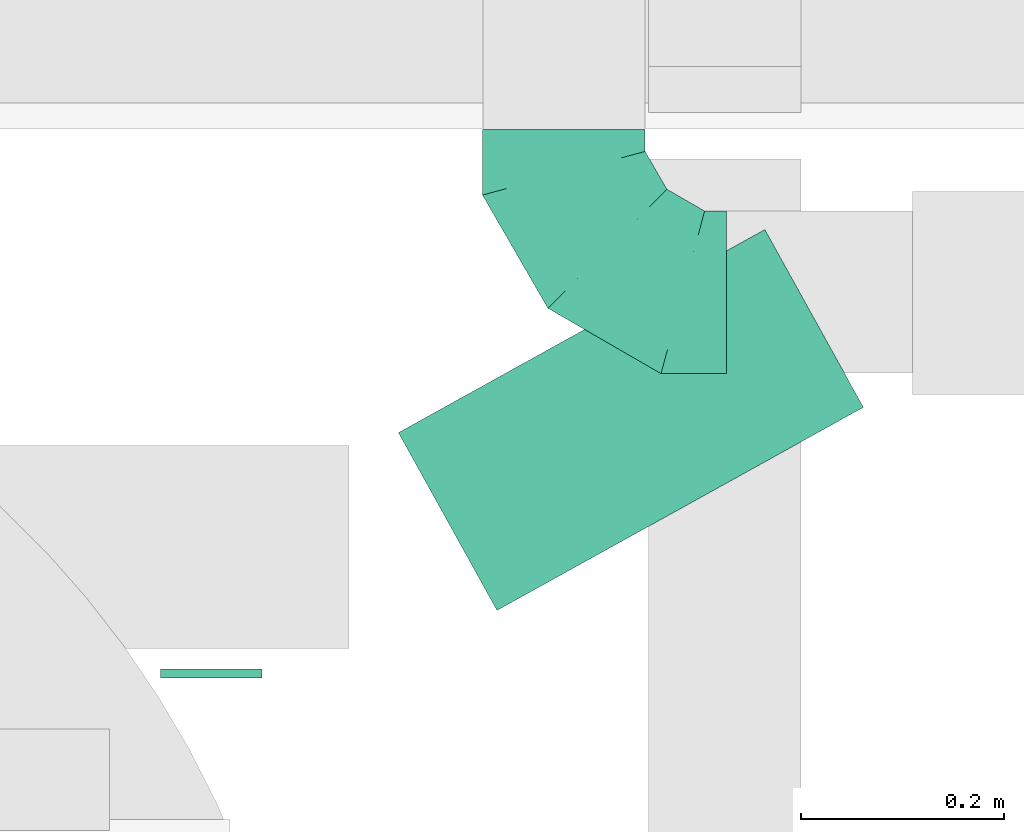
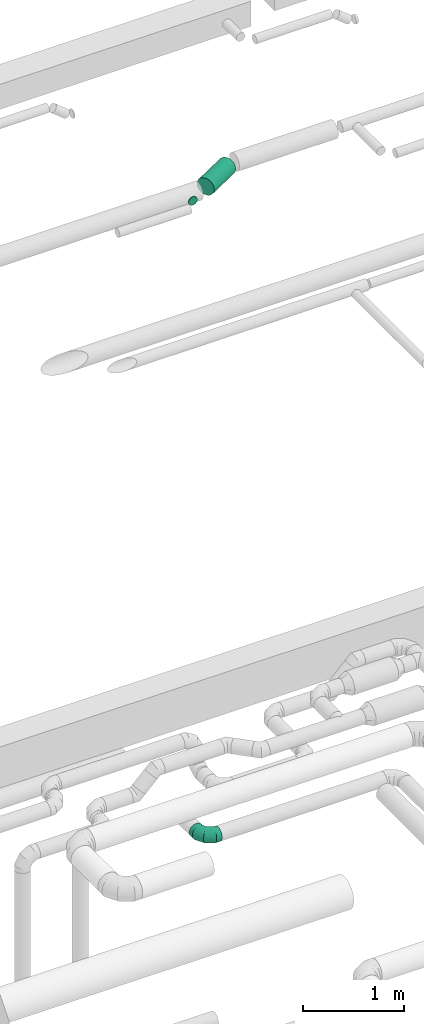
# One storey, part 284 of 337: 2 flow segments, 1 flow fitting.
"""IFC2X3 building model written with IfcOpenShell, lengths in millimetres."""

import ifcopenshell
import ifcopenshell.guid

model = None  # the IFC model being written
_history = None  # IfcOwnerHistory: only IFC2X3 demands one
_inside = {}  # id of a spatial element -> (the spatial element, [elements in it])
_under = {}  # id of a project, library or spatial element -> (it, [spatial elements below it])
_declared = {}  # id of a project -> (the project, [libraries it declares])
_typed = {}  # id of a type object -> (the type object, [elements of that type])
_made_of = {}  # id of a material, layer set ... -> (it, [elements and type objects made of it])


def new_model(schema):
    """Start an empty IFC model of exactly this schema.

    Asked for "IFC4X3", IfcOpenShell would pick the latest addendum, in which some entities
    have other attributes; the version numbers below select the first issue.
    IFC2X3 requires an IfcOwnerHistory on every rooted entity: one is made here for all.
    """
    global model, _history
    if schema == "IFC4X3":
        model = ifcopenshell.file(schema_version=(4, 3, 0, 0))
    else:
        model = ifcopenshell.file(schema=schema)
    _inside.clear()
    _under.clear()
    _declared.clear()
    _typed.clear()
    _made_of.clear()
    _history = None
    if model.schema == "IFC2X3":
        org = make("IfcOrganization", Name="unknown")
        user = make(
            "IfcPersonAndOrganization",
            ThePerson=make("IfcPerson", FamilyName="unknown"),
            TheOrganization=org,
        )
        app = make(
            "IfcApplication",
            ApplicationDeveloper=org,
            Version="unknown",
            ApplicationFullName="unknown",
            ApplicationIdentifier="unknown",
        )
        _history = make(
            "IfcOwnerHistory",
            OwningUser=user,
            OwningApplication=app,
            ChangeAction="ADDED",
            CreationDate=0,
        )
    return model


def make(cls, **values):
    """One entity of the class cls with the attributes given. An attribute that is None is left unset."""
    return model.create_entity(
        cls, **{name: value for name, value in values.items() if value is not None}
    )


def entity(cls, *values):
    """Any entity or typed value of the class cls, its attributes in the order of the schema. None: left unset."""
    e = model.create_entity(cls)
    for i, value in enumerate(values):
        if value is not None:
            e[i] = value
    return e


def rooted(cls, **values):
    """An entity with a GlobalId (a new one), such as an element, a storey or a relation."""
    return make(cls, GlobalId=ifcopenshell.guid.new(), OwnerHistory=_history, **values)


def si_unit(unit_type, name, prefix=None):
    """IfcSIUnit, for example si_unit("LENGTHUNIT", "METRE", prefix="MILLI")."""
    return make("IfcSIUnit", UnitType=unit_type, Prefix=prefix, Name=name)


def converted_unit(unit_type, name, factor, base, dimensions=None, offset=None):
    """IfcConversionBasedUnit, such as the inch: factor (a typed value) times the base unit."""
    return make(
        "IfcConversionBasedUnit"
        if offset is None
        else "IfcConversionBasedUnitWithOffset",
        ConversionOffset=offset,
        Dimensions=None
        if dimensions is None
        else entity("IfcDimensionalExponents", *dimensions),
        UnitType=unit_type,
        Name=name,
        ConversionFactor=make(
            "IfcMeasureWithUnit", ValueComponent=factor, UnitComponent=base
        ),
    )


def derived_unit(unit_type, elements):
    """IfcDerivedUnit: a product of units, each with its exponent."""
    return make(
        "IfcDerivedUnit",
        Elements=[
            make("IfcDerivedUnitElement", Unit=unit, Exponent=power)
            for unit, power in elements
        ],
        UnitType=unit_type,
    )


def assignment(units):
    """IfcUnitAssignment: the units of a project."""
    return None if units is None else make("IfcUnitAssignment", Units=units)


def point(xyz):
    """IfcCartesianPoint."""
    return None if xyz is None else make("IfcCartesianPoint", Coordinates=xyz)


def direction(xyz):
    """IfcDirection."""
    return None if xyz is None else make("IfcDirection", DirectionRatios=xyz)


def frame(location, z_axis=None, x_axis=None):
    """IfcAxis2Placement3D, a coordinate frame: its origin and axes. An axis left out is left unset."""
    return make(
        "IfcAxis2Placement3D",
        Location=point(location),
        Axis=direction(z_axis),
        RefDirection=direction(x_axis),
    )


def frame_2d(location, x_axis=None):
    """IfcAxis2Placement2D, a coordinate frame in the plane: its origin and x axis."""
    return make(
        "IfcAxis2Placement2D", Location=point(location), RefDirection=direction(x_axis)
    )


def origin():
    """The frame at (0, 0, 0) with its axes left unset."""
    return frame((0.0, 0.0, 0.0))


def origin_2d_with_axis():
    """The frame at (0, 0) in the plane with the x axis (1, 0) written out."""
    return frame_2d((0.0, 0.0), x_axis=(1.0, 0.0))


def place(relative_to, where):
    """IfcLocalPlacement: puts the frame where relative to a parent placement (None: the world)."""
    return make(
        "IfcLocalPlacement", PlacementRelTo=relative_to, RelativePlacement=where
    )


def context(
    kind, dimensions, precision=None, world=None, true_north=None, identifier=None
):
    """IfcGeometricRepresentationContext, for example the 3D "Model" context."""
    return make(
        "IfcGeometricRepresentationContext",
        ContextIdentifier=identifier,
        ContextType=kind,
        CoordinateSpaceDimension=dimensions,
        Precision=precision,
        WorldCoordinateSystem=world,
        TrueNorth=true_north,
    )


def subcontext(parent, identifier, kind, view, scale=None):
    """IfcGeometricRepresentationSubContext, for example "Body" below "Model"."""
    return make(
        "IfcGeometricRepresentationSubContext",
        ContextIdentifier=identifier,
        ContextType=kind,
        ParentContext=parent,
        TargetScale=scale,
        TargetView=view,
    )


def project(units=None, contexts=None):
    """IfcProject with its units and contexts."""
    return rooted(
        "IfcProject",
        Name="project",
        RepresentationContexts=contexts,
        UnitsInContext=assignment(units),
    )


def spatial(cls, under=None, at=None, **own):
    """A site, building, storey or space (cls), placed at a placement, below another one or the project."""
    s = rooted(cls, ObjectPlacement=at, **own)
    if under is not None:
        _under.setdefault(under.id(), (under, []))[1].append(s)
    return s


def profile(cls, at=None, kind="AREA", **sizes):
    """A parametric profile (cls). Its sizes go by their IFC names, for example OverallWidth=200.0."""
    return make(cls, ProfileType=kind, Position=at, **sizes)


def circle(**sizes):
    """IfcCircleProfileDef."""
    return profile("IfcCircleProfileDef", **sizes)


def extrude(swept, where, along, depth):
    """IfcExtrudedAreaSolid: the profile swept, set in the frame where, extruded along a direction by depth."""
    return make(
        "IfcExtrudedAreaSolid",
        SweptArea=swept,
        Position=where,
        ExtrudedDirection=direction(along),
        Depth=depth,
    )


def faces_of(points, faces, orient=None, outer=None):
    """IfcFace entities. A face is a list of loops; a loop is a list of indices into points, from 0.

    orient and outer hold one flag for each loop. By default every Orientation is true, the
    first loop of a face is its IfcFaceOuterBound and the others are IfcFaceBound.
    """
    made = []
    for i, loops in enumerate(faces):
        bounds = []
        for j, loop in enumerate(loops):
            is_outer = j == 0 if outer is None else outer[i][j]
            bounds.append(
                make(
                    "IfcFaceOuterBound" if is_outer else "IfcFaceBound",
                    Bound=make("IfcPolyLoop", Polygon=[points[k] for k in loop]),
                    Orientation=True if orient is None else orient[i][j],
                )
            )
        made.append(make("IfcFace", Bounds=bounds))
    return made


def faceted_brep(points, faces, orient=None, outer=None, voids=None):
    """IfcFacetedBrep: a solid bounded by flat faces; with voids (closed shells), ...WithVoids."""
    shared = [point(p) for p in points]
    hull = make("IfcClosedShell", CfsFaces=faces_of(shared, faces, orient, outer))
    if voids is None:
        return make("IfcFacetedBrep", Outer=hull)
    return make(
        "IfcFacetedBrepWithVoids",
        Outer=hull,
        Voids=[
            make(cls, CfsFaces=faces_of(shared, fs, o, b)) for cls, fs, o, b in voids
        ],
    )


def shape(context_of_items, identifier, shape_type, items):
    """IfcShapeRepresentation: the items that make up one representation, for example the "Body"."""
    return make(
        "IfcShapeRepresentation",
        ContextOfItems=context_of_items,
        RepresentationIdentifier=identifier,
        RepresentationType=shape_type,
        Items=items,
    )


def source(mapping_origin, context_of_items, identifier, shape_type, items):
    """IfcRepresentationMap: a shape defined once, which mapped items show again and again."""
    return make(
        "IfcRepresentationMap",
        MappingOrigin=mapping_origin,
        MappedRepresentation=shape(context_of_items, identifier, shape_type, items),
    )


def transform(
    local_origin,
    x_axis=None,
    y_axis=None,
    z_axis=None,
    scale=None,
    scale2=None,
    scale3=None,
    uniform=True,
):
    """IfcCartesianTransformationOperator3D, or its non-uniform kind. x_axis, y_axis, z_axis: its Axis1, 2, 3."""
    if uniform:
        return make(
            "IfcCartesianTransformationOperator3D",
            Axis1=direction(x_axis),
            Axis2=direction(y_axis),
            LocalOrigin=point(local_origin),
            Scale=scale,
            Axis3=direction(z_axis),
        )
    return make(
        "IfcCartesianTransformationOperator3DnonUniform",
        Axis1=direction(x_axis),
        Axis2=direction(y_axis),
        LocalOrigin=point(local_origin),
        Scale=scale,
        Axis3=direction(z_axis),
        Scale2=scale2,
        Scale3=scale3,
    )


def mapped(mapping_source, mapping_target):
    """IfcMappedItem: shows the shape of a source again, moved by a transform."""
    return make(
        "IfcMappedItem", MappingSource=mapping_source, MappingTarget=mapping_target
    )


def material(Name=None, Category=None):
    """IfcMaterial."""
    return make("IfcMaterial", Name=Name, Category=Category)


def made_of(thing, what):
    """Note that an element or type object is made of a material, layer set ...; save() writes the relation."""
    if what is not None:
        _made_of.setdefault(what.id(), (what, []))[1].append(thing)
    return thing


def type_object(cls, material=None, **own):
    """A type object (cls), such as IfcWallType, which elements share."""
    return made_of(rooted(cls, **own), material)


def type_shapes(of_type, sources):
    """Give a type object the sources (RepresentationMaps) that its elements show as mapped items."""
    of_type.RepresentationMaps = sources


def element(
    cls,
    number,
    at=None,
    inside=None,
    cuts=None,
    type_object=None,
    material=None,
    context=None,
    identifier="Body",
    shape_type=None,
    held_by="IfcProductDefinitionShape",
    body=None,
    shapes=None,
    **own,
):
    """One element of the class cls, such as IfcWall. Its Tag is "e" and its number.

    at: its placement. inside: the storey or other place that contains it. cuts: it is an
    opening in that element (IfcRelVoidsElement). A single representation is given by context,
    identifier, shape_type and body (its items); several are given by shapes. held_by: the class
    of the entity that holds the representations. save() writes the other relations.
    """
    e = rooted(cls, Tag="e%d" % number, ObjectPlacement=at, **own)
    if body is not None:
        shapes = [shape(context, identifier, shape_type, body)]
    if shapes is not None:
        e.Representation = make(held_by, Representations=shapes)
    if inside is not None:
        _inside.setdefault(inside.id(), (inside, []))[1].append(e)
    if cuts is not None:
        rooted(
            "IfcRelVoidsElement", RelatingBuildingElement=cuts, RelatedOpeningElement=e
        )
    if type_object is not None:
        _typed.setdefault(type_object.id(), (type_object, []))[1].append(e)
    return made_of(e, material)


def aggregate(whole, parts):
    """IfcRelAggregates: a whole, such as a stair, and the parts it consists of."""
    return rooted("IfcRelAggregates", RelatingObject=whole, RelatedObjects=parts)


def save(model, path):
    """Write the relations noted so far, then the file.

    IfcRelAggregates (storeys below a building ...), IfcRelContainedInSpatialStructure (elements
    in a storey), IfcRelDefinesByType, IfcRelAssociatesMaterial and IfcRelDeclares: one each for
    every whole, place, type object, material and project.
    """
    for whole, parts in _under.values():
        aggregate(whole, parts)
    for where, things in _inside.values():
        rooted(
            "IfcRelContainedInSpatialStructure",
            RelatedElements=things,
            RelatingStructure=where,
        )
    for kind, things in _typed.values():
        rooted("IfcRelDefinesByType", RelatedObjects=things, RelatingType=kind)
    for what, things in _made_of.values():
        rooted("IfcRelAssociatesMaterial", RelatedObjects=things, RelatingMaterial=what)
    for by, libraries in _declared.values():
        rooted("IfcRelDeclares", RelatingContext=by, RelatedDefinitions=libraries)
    model.write(path)


model = new_model("IFC2X3")

# Units and contexts
model_context = context("Model", 3, precision=0.01, world=origin(), true_north=direction((6.12303176911189e-17, 1.0)))
body_context = subcontext(model_context, "Body", "Model", "MODEL_VIEW")
ifc_project = project(units=[si_unit("LENGTHUNIT", "METRE", prefix="MILLI"), si_unit("AREAUNIT", "SQUARE_METRE"), si_unit("VOLUMEUNIT", "CUBIC_METRE"), converted_unit("PLANEANGLEUNIT", "DEGREE", entity("IfcRatioMeasure", 0.0174532925199433), si_unit("PLANEANGLEUNIT", "RADIAN"), dimensions=[0, 0, 0, 0, 0, 0, 0]), si_unit("MASSUNIT", "GRAM", prefix="KILO"), derived_unit("MASSDENSITYUNIT", [(si_unit("MASSUNIT", "GRAM", prefix="KILO"), 1), (si_unit("LENGTHUNIT", "METRE"), -3)]), derived_unit("MOMENTOFINERTIAUNIT", [(si_unit("LENGTHUNIT", "METRE"), 4)]), si_unit("TIMEUNIT", "SECOND"), si_unit("FREQUENCYUNIT", "HERTZ"), si_unit("THERMODYNAMICTEMPERATUREUNIT", "DEGREE_CELSIUS"), derived_unit("THERMALTRANSMITTANCEUNIT", [(si_unit("MASSUNIT", "GRAM", prefix="KILO"), 1), (si_unit("THERMODYNAMICTEMPERATUREUNIT", "KELVIN"), -1), (si_unit("TIMEUNIT", "SECOND"), -3)]), derived_unit("VOLUMETRICFLOWRATEUNIT", [(si_unit("LENGTHUNIT", "METRE"), 3), (si_unit("TIMEUNIT", "SECOND"), -1)]), derived_unit("MASSFLOWRATEUNIT", [(si_unit("MASSUNIT", "GRAM", prefix="KILO"), 1), (si_unit("TIMEUNIT", "SECOND"), -1)]), derived_unit("ROTATIONALFREQUENCYUNIT", [(si_unit("TIMEUNIT", "SECOND"), -1)]), si_unit("ELECTRICCURRENTUNIT", "AMPERE"), si_unit("ELECTRICVOLTAGEUNIT", "VOLT"), si_unit("POWERUNIT", "WATT"), si_unit("FORCEUNIT", "NEWTON", prefix="KILO"), si_unit("ILLUMINANCEUNIT", "LUX"), si_unit("LUMINOUSFLUXUNIT", "LUMEN"), si_unit("LUMINOUSINTENSITYUNIT", "CANDELA"), derived_unit("USERDEFINED", [(si_unit("MASSUNIT", "GRAM", prefix="KILO"), -1), (si_unit("LENGTHUNIT", "METRE"), -2), (si_unit("TIMEUNIT", "SECOND"), 3), (si_unit("LUMINOUSFLUXUNIT", "LUMEN"), 1)]), derived_unit("LINEARVELOCITYUNIT", [(si_unit("LENGTHUNIT", "METRE"), 1), (si_unit("TIMEUNIT", "SECOND"), -1)]), si_unit("PRESSUREUNIT", "PASCAL"), derived_unit("USERDEFINED", [(si_unit("LENGTHUNIT", "METRE"), -2), (si_unit("MASSUNIT", "GRAM", prefix="KILO"), 1), (si_unit("TIMEUNIT", "SECOND"), -2)]), derived_unit("LINEARFORCEUNIT", [(si_unit("MASSUNIT", "GRAM", prefix="KILO"), 1), (si_unit("LENGTHUNIT", "METRE"), 1), (si_unit("TIMEUNIT", "SECOND"), -2), (si_unit("LENGTHUNIT", "METRE"), -1)]), derived_unit("PLANARFORCEUNIT", [(si_unit("MASSUNIT", "GRAM", prefix="KILO"), 1), (si_unit("LENGTHUNIT", "METRE"), 1), (si_unit("TIMEUNIT", "SECOND"), -2), (si_unit("LENGTHUNIT", "METRE"), -2)])], contexts=[model_context])

# Site, building, storey
site_placement = place(None, origin())
site = spatial("IfcSite", under=ifc_project, at=site_placement, CompositionType="ELEMENT")
building_placement = place(site_placement, origin())
building = spatial("IfcBuilding", under=site, at=building_placement, CompositionType="ELEMENT")
storey_placement = place(building_placement, origin())
storey = spatial("IfcBuildingStorey", under=building, at=storey_placement, CompositionType="ELEMENT", Elevation=0.0)

# Flow segments
duct_segment_type = type_object("IfcDuctSegmentType", PredefinedType="NOTDEFINED")
flow_segment_1_placement = place(storey_placement, frame((50318.45, 17299.24, 11348.4)))
element("IfcFlowSegment", 1, at=flow_segment_1_placement, inside=storey, type_object=duct_segment_type, context=body_context, shape_type="SweptSolid", body=[
    extrude(circle(Radius=50.0, at=origin_2d_with_axis()), frame((51.6, 0.0, 51.6), z_axis=(0.0, 1.0, 0.0), x_axis=(1.0, 0.0, 0.0)), (0.0, 0.0, 1.0), 8.86893952756495),
])
flow_segment_2_placement = place(storey_placement, frame((50552.46, 17364.12, 11298.4)))
element("IfcFlowSegment", 2, at=flow_segment_2_placement, inside=storey, type_object=duct_segment_type, context=body_context, shape_type="SweptSolid", body=[
    extrude(circle(Radius=100.0, at=origin_2d_with_axis()), frame((50.08, 89.06, 101.6), z_axis=(0.874619707139382, 0.484809620246362, 0.0), x_axis=(-0.484809620246362, 0.874619707139382, 0.0)), (0.0, 0.0, 1.0), 412.219301164494),
])

# Flow fitting
ifc_material = material()
duct_fitting_type = type_object("IfcDuctFittingType", PredefinedType="NOTDEFINED", material=ifc_material)
shared_shape = source(origin(), body_context, "Body", "Brep", [
    faceted_brep([(-160.0, 0.0, -80.0), (-160.0, -20.71, -77.27), (-160.0, -40.0, -69.28), (-160.0, -56.57, -56.57), (-160.0, -69.28, -40.0), (-160.0, -77.27, -20.71), (-160.0, -80.0, 0.0), (-160.0, -77.27, 20.71), (-160.0, -69.28, 40.0), (-160.0, -56.57, 56.57), (-160.0, -40.0, 69.28), (-160.0, -20.71, 77.27), (-160.0, 0.0, 80.0), (-160.0, 20.71, 77.27), (-160.0, 40.0, 69.28), (-160.0, 56.57, 56.57), (-160.0, 69.28, 40.0), (-160.0, 77.27, 20.71), (-160.0, 80.0, 0.0), (-160.0, 77.27, -20.71), (-160.0, 69.28, -40.0), (-160.0, 56.57, -56.57), (-160.0, 40.0, -69.28), (-160.0, 20.71, -77.27), (-122.68, 20.71, 77.27), (-127.85, 40.0, 69.28), (-117.13, 0.0, 80.0), (-132.29, 56.57, 56.57), (-137.83, 77.27, 20.71), (-138.56, 80.0, 0.0), (-135.69, 69.28, 40.0), (-135.69, 69.28, -40.0), (-132.29, 56.57, -56.57), (-137.83, 77.27, -20.71), (-122.68, 20.71, -77.27), (-117.13, 0.0, -80.0), (-127.85, 40.0, -69.28), (-111.58, -20.71, -77.27), (-106.41, -40.0, -69.28), (-101.97, -56.57, -56.57), (-98.56, -69.28, -40.0), (-96.42, -77.27, -20.71), (-95.69, -80.0, 0.0), (-96.42, -77.27, 20.71), (-98.56, -69.28, 40.0), (-101.97, -56.57, 56.57), (-106.41, -40.0, 69.28), (-111.58, -20.71, 77.27), (-58.03, 58.03, 77.27), (-72.15, 72.15, 69.28), (-42.87, 42.87, 80.0), (-84.28, 84.28, 56.57), (-93.59, 93.59, 40.0), (-99.44, 99.44, 20.71), (-101.44, 101.44, 0.0), (-99.44, 99.44, -20.71), (-93.59, 93.59, -40.0), (-84.28, 84.28, -56.57), (-58.03, 58.03, -77.27), (-42.87, 42.87, -80.0), (-72.15, 72.15, -69.28), (-27.71, 27.71, -77.27), (-13.59, 13.59, -69.28), (-1.46, 1.46, -56.57), (7.85, -7.85, -40.0), (13.7, -13.7, -20.71), (15.69, -15.69, 0.0), (13.7, -13.7, 20.71), (7.85, -7.85, 40.0), (-1.46, 1.46, 56.57), (-13.59, 13.59, 69.28), (-27.71, 27.71, 77.27), (-20.71, 122.68, 77.27), (-40.0, 127.85, 69.28), (0.0, 117.13, 80.0), (-56.57, 132.29, 56.57), (-69.28, 135.69, 40.0), (-77.27, 137.83, 20.71), (-80.0, 138.56, 0.0), (-77.27, 137.83, -20.71), (-69.28, 135.69, -40.0), (-56.57, 132.29, -56.57), (-20.71, 122.68, -77.27), (0.0, 117.13, -80.0), (-40.0, 127.85, -69.28), (20.71, 111.58, -77.27), (40.0, 106.41, -69.28), (56.57, 101.97, -56.57), (69.28, 98.56, -40.0), (77.27, 96.42, -20.71), (80.0, 95.69, 0.0), (77.27, 96.42, 20.71), (69.28, 98.56, 40.0), (56.57, 101.97, 56.57), (40.0, 106.41, 69.28), (20.71, 111.58, 77.27), (-20.71, 160.0, -77.27), (-40.0, 160.0, -69.28), (-56.57, 160.0, -56.57), (-69.28, 160.0, -40.0), (-77.27, 160.0, -20.71), (-80.0, 160.0, 0.0), (-77.27, 160.0, 20.71), (-69.28, 160.0, 40.0), (-56.57, 160.0, 56.57), (-40.0, 160.0, 69.28), (-20.71, 160.0, 77.27), (0.0, 160.0, 80.0), (20.71, 160.0, 77.27), (40.0, 160.0, 69.28), (56.57, 160.0, 56.57), (69.28, 160.0, 40.0), (77.27, 160.0, 20.71), (80.0, 160.0, 0.0), (77.27, 160.0, -20.71), (69.28, 160.0, -40.0), (56.57, 160.0, -56.57), (40.0, 160.0, -69.28), (20.71, 160.0, -77.27), (0.0, 160.0, -80.0)], [[[0, 1, 2, 3, 4, 5, 6, 7, 8, 9, 10, 11, 12, 13, 14, 15, 16, 17, 18, 19, 20, 21, 22, 23]], [[24, 25, 14, 13]], [[26, 24, 13, 12]], [[14, 25, 27, 15]], [[28, 29, 18, 17]], [[30, 28, 17, 16]], [[15, 27, 30, 16]], [[20, 31, 32, 21]], [[33, 31, 20, 19]], [[18, 29, 33, 19]], [[34, 35, 0, 23]], [[36, 34, 23, 22]], [[32, 36, 22, 21]], [[1, 0, 35, 37]], [[2, 1, 37, 38]], [[3, 2, 38, 39]], [[5, 4, 40, 41]], [[6, 5, 41, 42]], [[39, 40, 4, 3]], [[6, 42, 43, 7]], [[7, 43, 44, 8]], [[8, 44, 45, 9]], [[9, 45, 46, 10]], [[10, 46, 47, 11]], [[26, 12, 11, 47]], [[48, 49, 25, 24]], [[50, 48, 24, 26]], [[27, 25, 49, 51]], [[52, 53, 28, 30]], [[51, 52, 30, 27]], [[29, 28, 53, 54]], [[55, 56, 31, 33]], [[54, 55, 33, 29]], [[32, 31, 56, 57]], [[58, 59, 35, 34]], [[60, 58, 34, 36]], [[57, 60, 36, 32]], [[37, 35, 59, 61]], [[38, 37, 61, 62]], [[39, 38, 62, 63]], [[41, 40, 64, 65]], [[42, 41, 65, 66]], [[63, 64, 40, 39]], [[43, 42, 66, 67]], [[44, 43, 67, 68]], [[68, 69, 45, 44]], [[46, 45, 69, 70]], [[47, 46, 70, 71]], [[26, 47, 71, 50]], [[72, 73, 49, 48]], [[74, 72, 48, 50]], [[51, 49, 73, 75]], [[76, 77, 53, 52]], [[75, 76, 52, 51]], [[54, 53, 77, 78]], [[79, 80, 56, 55]], [[78, 79, 55, 54]], [[57, 56, 80, 81]], [[82, 83, 59, 58]], [[84, 82, 58, 60]], [[81, 84, 60, 57]], [[61, 59, 83, 85]], [[62, 61, 85, 86]], [[63, 62, 86, 87]], [[65, 64, 88, 89]], [[66, 65, 89, 90]], [[87, 88, 64, 63]], [[67, 66, 90, 91]], [[68, 67, 91, 92]], [[92, 93, 69, 68]], [[70, 69, 93, 94]], [[71, 70, 94, 95]], [[50, 71, 95, 74]], [[96, 97, 98, 99, 100, 101, 102, 103, 104, 105, 106, 107, 108, 109, 110, 111, 112, 113, 114, 115, 116, 117, 118, 119]], [[72, 74, 107, 106]], [[73, 72, 106, 105]], [[75, 73, 105, 104]], [[77, 76, 103, 102]], [[78, 77, 102, 101]], [[75, 104, 103, 76]], [[78, 101, 100, 79]], [[79, 100, 99, 80]], [[80, 99, 98, 81]], [[84, 97, 96, 82]], [[82, 96, 119, 83]], [[84, 81, 98, 97]], [[118, 117, 86, 85]], [[119, 118, 85, 83]], [[116, 87, 86, 117]], [[88, 115, 114, 89]], [[89, 114, 113, 90]], [[115, 88, 87, 116]], [[112, 111, 92, 91]], [[113, 112, 91, 90]], [[111, 110, 93, 92]], [[95, 94, 109, 108]], [[74, 95, 108, 107]], [[110, 109, 94, 93]]]),
])
type_shapes(duct_fitting_type, [shared_shape])
flow_fitting_placement = place(storey_placement, frame((50716.74, 17678.74, 3380.0), z_axis=(0.0, 0.0, 1.0), x_axis=(0.0, -1.0, 0.0)))
element("IfcFlowFitting", 3, at=flow_fitting_placement, inside=storey, type_object=duct_fitting_type, material=ifc_material, context=body_context, shape_type="MappedRepresentation", body=[
    mapped(shared_shape, transform((0.0, 0.0, 0.0), scale=1.0)),
])

save(model, "model.ifc")
